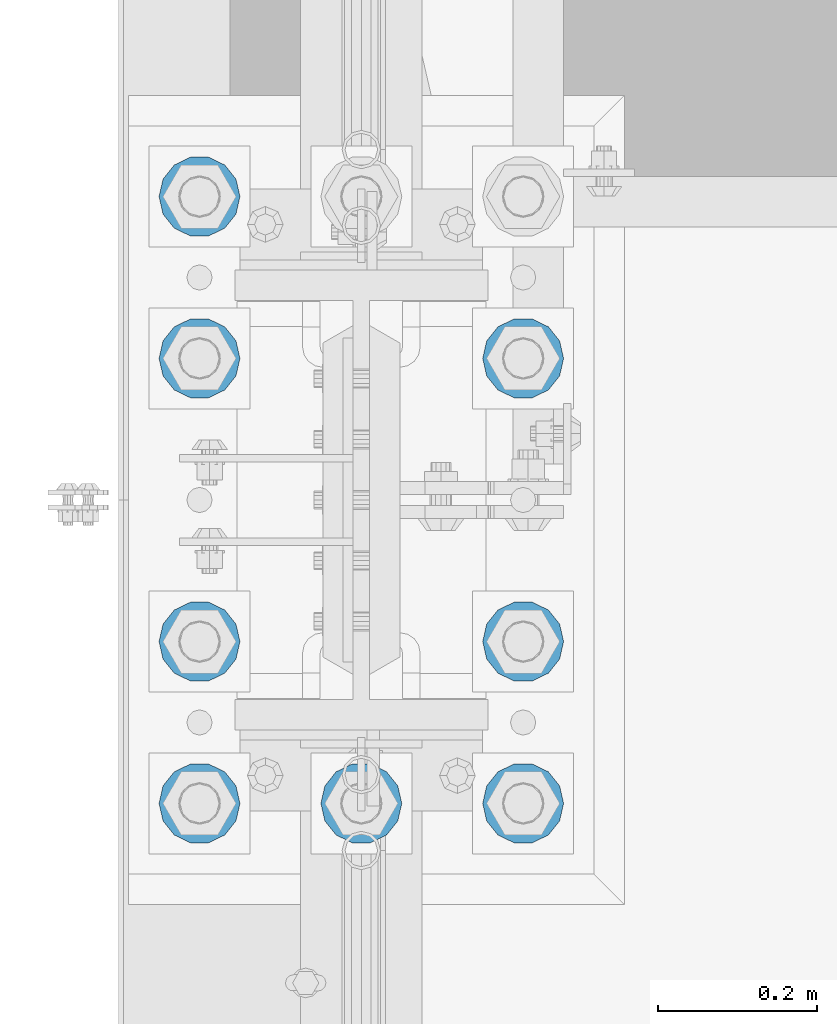
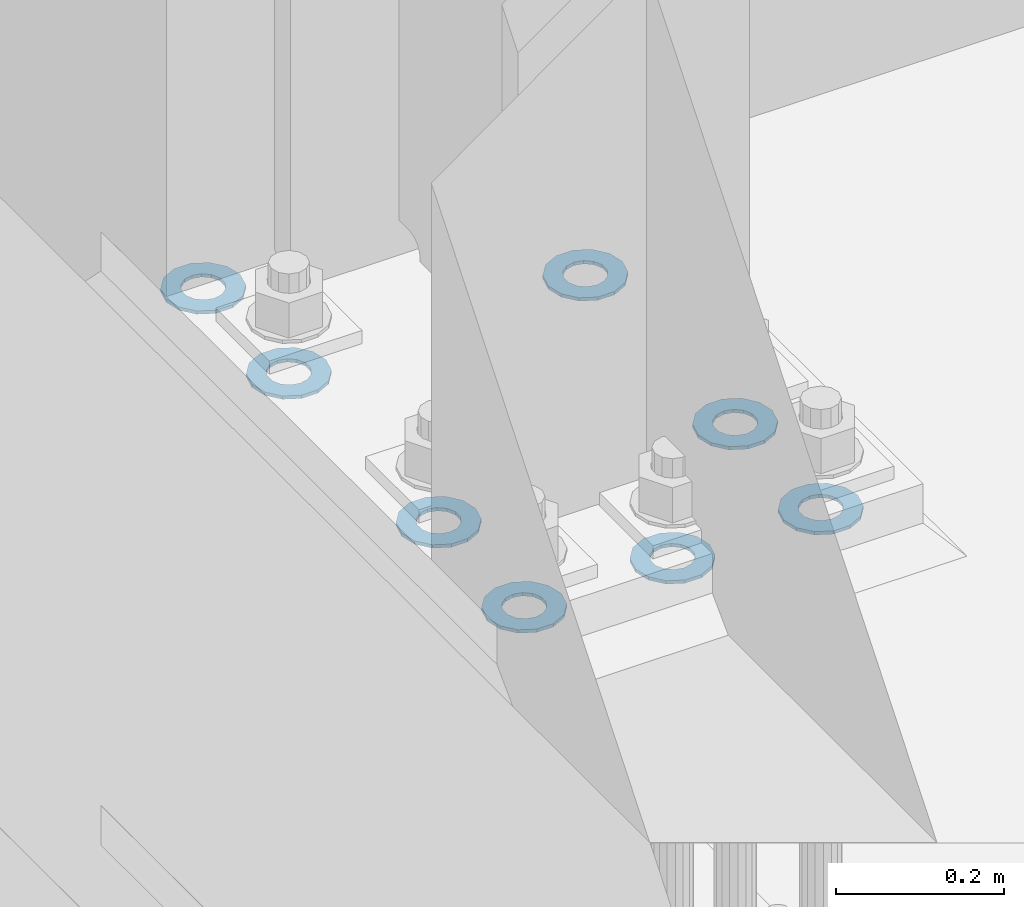
# One storey, part 833 of 1876: 8 columns, 1 element without a shape of its own.
"""IFC2X3 building model written with IfcOpenShell, lengths in millimetres."""

from ifc_helpers import new_model, si_unit, frame, origin_with_axes, place, context, subcontext, project, spatial, faceted_brep, material, type_object, element, aggregate, save


model = new_model("IFC2X3")

# Units and contexts
model_context = context("Model", 3, precision=1e-05, world=origin_with_axes())
body_context = subcontext(model_context, "Body", "Model", "MODEL_VIEW")
ifc_project = project(units=[si_unit("LENGTHUNIT", "METRE", prefix="MILLI"), si_unit("AREAUNIT", "SQUARE_METRE"), si_unit("VOLUMEUNIT", "CUBIC_METRE"), si_unit("MASSUNIT", "GRAM", prefix="KILO"), si_unit("TIMEUNIT", "SECOND"), si_unit("PLANEANGLEUNIT", "RADIAN"), si_unit("SOLIDANGLEUNIT", "STERADIAN"), si_unit("THERMODYNAMICTEMPERATUREUNIT", "DEGREE_CELSIUS"), si_unit("LUMINOUSINTENSITYUNIT", "LUMEN")], contexts=[model_context])

# Site, building, storey
site_placement = place(None, origin_with_axes())
site = spatial("IfcSite", under=ifc_project, at=site_placement, CompositionType="ELEMENT")
building_placement = place(site_placement, origin_with_axes())
building = spatial("IfcBuilding", under=site, at=building_placement, Name="Undefined", CompositionType="ELEMENT")
storey_placement = place(building_placement, origin_with_axes())
storey = spatial("IfcBuildingStorey", under=building, at=storey_placement, Name="Undefined", CompositionType="ELEMENT", Elevation=0.0)

# Assembly, columns
assembly_placement = place(storey_placement, origin_with_axes())
assembly = element("IfcElementAssembly", 1, at=assembly_placement, inside=storey, Name="TEMPLATE", AssemblyPlace="NOTDEFINED", PredefinedType="RIGID_FRAME")
ifc_material = material(Name="STEEL/F436")
column_type = type_object("IfcColumnType", Name="2_WASHER", PredefinedType="NOTDEFINED")
column_1_placement = place(assembly_placement, frame((-203.2, 1143.0, 38.1), z_axis=(0.0, -1.0, 0.0), x_axis=(0.0, 0.0, -1.0)))
column_1 = element("IfcColumn", 2, at=column_1_placement, type_object=column_type, material=ifc_material, Name="WASHER", ObjectType="2_WASHER", context=body_context, shape_type="Brep", body=[
    faceted_brep([(0.0, -50.7999992370605, 9.09494701772928e-13), (0.0, -45.7692178020588, -22.0412936161442), (4.7625, -45.7692178020588, -22.0412936161442), (4.7625, -50.7999992370605, 9.09494701772928e-13), (0.0, -31.6732814587394, -39.7170387128856), (4.7625, -31.6732814587394, -39.7170387128856), (0.0, -11.3040632752118, -49.5263371950259), (4.7625, -11.3040632752118, -49.5263371950259), (0.0, 11.30406327521, -49.5263371950264), (4.7625, 11.30406327521, -49.5263371950264), (0.0, 31.6732814587385, -39.7170387128867), (4.7625, 31.6732814587385, -39.7170387128867), (0.0, 45.7692178020579, -22.041293616146), (4.7625, 45.7692178020579, -22.041293616146), (0.0, 50.7999992370605, -9.09494701772928e-13), (4.7625, 50.7999992370605, -9.09494701772928e-13), (0.0, 45.7692178020588, 22.0412936161442), (4.7625, 45.7692178020588, 22.0412936161442), (0.0, 31.6732814587394, 39.7170387128856), (4.7625, 31.6732814587394, 39.7170387128856), (0.0, 11.3040632752118, 49.5263371950259), (4.7625, 11.3040632752118, 49.5263371950259), (0.0, -11.30406327521, 49.5263371950264), (4.7625, -11.30406327521, 49.5263371950264), (0.0, -31.6732814587385, 39.7170387128867), (4.7625, -31.6732814587385, 39.7170387128867), (0.0, -45.7692178020579, 22.041293616146), (4.7625, -45.7692178020579, 22.041293616146), (0.0, 0.0, 26.9869995117188), (0.0, 11.7093983825444, 24.3146012721213), (4.7625, 11.7093983825444, 24.3146012721213), (4.7625, 0.0, 26.9869995117188), (0.0, 21.0996520289491, 16.8262864224157), (4.7625, 21.0996520289491, 16.8262864224157), (0.0, 26.3108629296712, 6.00524193584533), (4.7625, 26.3108629296712, 6.00524193584533), (0.0, 26.3108629296712, -6.00524193584533), (4.7625, 26.3108629296712, -6.00524193584533), (0.0, 21.0996520289491, -16.8262864224157), (4.7625, 21.0996520289491, -16.8262864224157), (0.0, 11.7093983825444, -24.3146012721213), (4.7625, 11.7093983825444, -24.3146012721213), (0.0, 0.0, -26.9869995117188), (4.7625, 0.0, -26.9869995117188), (0.0, -11.7093983825444, -24.3146012721213), (4.7625, -11.7093983825444, -24.3146012721213), (0.0, -21.0996520289491, -16.8262864224157), (4.7625, -21.0996520289491, -16.8262864224157), (0.0, -26.3108629296712, -6.00524193584533), (4.7625, -26.3108629296712, -6.00524193584533), (0.0, -26.3108629296712, 6.00524193584533), (4.7625, -26.3108629296712, 6.00524193584533), (0.0, -21.0996520289491, 16.8262864224157), (4.7625, -21.0996520289491, 16.8262864224157), (0.0, -11.7093983825444, 24.3146012721213), (4.7625, -11.7093983825444, 24.3146012721213)], [[[0, 1, 2, 3]], [[1, 4, 5, 2]], [[4, 6, 7, 5]], [[6, 8, 9, 7]], [[8, 10, 11, 9]], [[10, 12, 13, 11]], [[12, 14, 15, 13]], [[14, 16, 17, 15]], [[16, 18, 19, 17]], [[18, 20, 21, 19]], [[20, 22, 23, 21]], [[22, 24, 25, 23]], [[24, 26, 27, 25]], [[26, 0, 3, 27]], [[28, 29, 30, 31]], [[29, 32, 33, 30]], [[32, 34, 35, 33]], [[34, 36, 37, 35]], [[36, 38, 39, 37]], [[38, 40, 41, 39]], [[40, 42, 43, 41]], [[42, 44, 45, 43]], [[44, 46, 47, 45]], [[46, 48, 49, 47]], [[48, 50, 51, 49]], [[50, 52, 53, 51]], [[52, 54, 55, 53]], [[54, 28, 31, 55]], [[5, 7, 9, 11, 13, 15, 17, 19, 21, 23, 25, 27, 3, 2], [33, 35, 37, 39, 41, 43, 45, 47, 49, 51, 53, 55, 31, 30]], [[26, 24, 22, 20, 18, 16, 14, 12, 10, 8, 6, 4, 1, 0], [54, 52, 50, 48, 46, 44, 42, 40, 38, 36, 34, 32, 29, 28]]]),
])
column_2_placement = place(assembly_placement, frame((0.0, 1143.0, 38.1), z_axis=(0.0, -1.0, 0.0), x_axis=(0.0, 0.0, -1.0)))
column_2 = element("IfcColumn", 3, at=column_2_placement, type_object=column_type, material=ifc_material, Name="WASHER", ObjectType="2_WASHER", context=body_context, shape_type="Brep", body=[
    faceted_brep([(0.0, -50.7999992370605, 9.09494701772928e-13), (0.0, -45.7692178020588, -22.0412936161442), (4.7625, -45.7692178020588, -22.0412936161442), (4.7625, -50.7999992370605, 9.09494701772928e-13), (0.0, -31.6732814587394, -39.7170387128856), (4.7625, -31.6732814587394, -39.7170387128856), (0.0, -11.3040632752118, -49.5263371950259), (4.7625, -11.3040632752118, -49.5263371950259), (0.0, 11.30406327521, -49.5263371950264), (4.7625, 11.30406327521, -49.5263371950264), (0.0, 31.6732814587385, -39.7170387128867), (4.7625, 31.6732814587385, -39.7170387128867), (0.0, 45.7692178020579, -22.041293616146), (4.7625, 45.7692178020579, -22.041293616146), (0.0, 50.7999992370605, -9.09494701772928e-13), (4.7625, 50.7999992370605, -9.09494701772928e-13), (0.0, 45.7692178020588, 22.0412936161442), (4.7625, 45.7692178020588, 22.0412936161442), (0.0, 31.6732814587394, 39.7170387128856), (4.7625, 31.6732814587394, 39.7170387128856), (0.0, 11.3040632752118, 49.5263371950259), (4.7625, 11.3040632752118, 49.5263371950259), (0.0, -11.30406327521, 49.5263371950264), (4.7625, -11.30406327521, 49.5263371950264), (0.0, -31.6732814587385, 39.7170387128867), (4.7625, -31.6732814587385, 39.7170387128867), (0.0, -45.7692178020579, 22.041293616146), (4.7625, -45.7692178020579, 22.041293616146), (0.0, 0.0, 26.9869995117188), (0.0, 11.7093983825444, 24.3146012721213), (4.7625, 11.7093983825444, 24.3146012721213), (4.7625, 0.0, 26.9869995117188), (0.0, 21.0996520289491, 16.8262864224157), (4.7625, 21.0996520289491, 16.8262864224157), (0.0, 26.3108629296712, 6.00524193584533), (4.7625, 26.3108629296712, 6.00524193584533), (0.0, 26.3108629296712, -6.00524193584533), (4.7625, 26.3108629296712, -6.00524193584533), (0.0, 21.0996520289491, -16.8262864224157), (4.7625, 21.0996520289491, -16.8262864224157), (0.0, 11.7093983825444, -24.3146012721213), (4.7625, 11.7093983825444, -24.3146012721213), (0.0, 0.0, -26.9869995117188), (4.7625, 0.0, -26.9869995117188), (0.0, -11.7093983825444, -24.3146012721213), (4.7625, -11.7093983825444, -24.3146012721213), (0.0, -21.0996520289491, -16.8262864224157), (4.7625, -21.0996520289491, -16.8262864224157), (0.0, -26.3108629296712, -6.00524193584533), (4.7625, -26.3108629296712, -6.00524193584533), (0.0, -26.3108629296712, 6.00524193584533), (4.7625, -26.3108629296712, 6.00524193584533), (0.0, -21.0996520289491, 16.8262864224157), (4.7625, -21.0996520289491, 16.8262864224157), (0.0, -11.7093983825444, 24.3146012721213), (4.7625, -11.7093983825444, 24.3146012721213)], [[[0, 1, 2, 3]], [[1, 4, 5, 2]], [[4, 6, 7, 5]], [[6, 8, 9, 7]], [[8, 10, 11, 9]], [[10, 12, 13, 11]], [[12, 14, 15, 13]], [[14, 16, 17, 15]], [[16, 18, 19, 17]], [[18, 20, 21, 19]], [[20, 22, 23, 21]], [[22, 24, 25, 23]], [[24, 26, 27, 25]], [[26, 0, 3, 27]], [[28, 29, 30, 31]], [[29, 32, 33, 30]], [[32, 34, 35, 33]], [[34, 36, 37, 35]], [[36, 38, 39, 37]], [[38, 40, 41, 39]], [[40, 42, 43, 41]], [[42, 44, 45, 43]], [[44, 46, 47, 45]], [[46, 48, 49, 47]], [[48, 50, 51, 49]], [[50, 52, 53, 51]], [[52, 54, 55, 53]], [[54, 28, 31, 55]], [[5, 7, 9, 11, 13, 15, 17, 19, 21, 23, 25, 27, 3, 2], [33, 35, 37, 39, 41, 43, 45, 47, 49, 51, 53, 55, 31, 30]], [[26, 24, 22, 20, 18, 16, 14, 12, 10, 8, 6, 4, 1, 0], [54, 52, 50, 48, 46, 44, 42, 40, 38, 36, 34, 32, 29, 28]]]),
])
column_3_placement = place(assembly_placement, frame((203.2, 1143.0, 38.1), z_axis=(0.0, 1.0, 0.0), x_axis=(0.0, 0.0, -1.0)))
column_3 = element("IfcColumn", 4, at=column_3_placement, type_object=column_type, material=ifc_material, Name="WASHER", ObjectType="2_WASHER", context=body_context, shape_type="Brep", body=[
    faceted_brep([(0.0, -50.7999992370605, 9.09494701772928e-13), (0.0, -45.7692178020588, -22.0412936161442), (4.7625, -45.7692178020588, -22.0412936161442), (4.7625, -50.7999992370605, 9.09494701772928e-13), (0.0, -31.6732814587394, -39.7170387128856), (4.7625, -31.6732814587394, -39.7170387128856), (0.0, -11.3040632752118, -49.5263371950259), (4.7625, -11.3040632752118, -49.5263371950259), (0.0, 11.30406327521, -49.5263371950264), (4.7625, 11.30406327521, -49.5263371950264), (0.0, 31.6732814587385, -39.7170387128867), (4.7625, 31.6732814587385, -39.7170387128867), (0.0, 45.7692178020579, -22.041293616146), (4.7625, 45.7692178020579, -22.041293616146), (0.0, 50.7999992370605, -9.09494701772928e-13), (4.7625, 50.7999992370605, -9.09494701772928e-13), (0.0, 45.7692178020588, 22.0412936161442), (4.7625, 45.7692178020588, 22.0412936161442), (0.0, 31.6732814587394, 39.7170387128856), (4.7625, 31.6732814587394, 39.7170387128856), (0.0, 11.3040632752118, 49.5263371950259), (4.7625, 11.3040632752118, 49.5263371950259), (0.0, -11.30406327521, 49.5263371950264), (4.7625, -11.30406327521, 49.5263371950264), (0.0, -31.6732814587385, 39.7170387128867), (4.7625, -31.6732814587385, 39.7170387128867), (0.0, -45.7692178020579, 22.041293616146), (4.7625, -45.7692178020579, 22.041293616146), (0.0, 0.0, 26.9869995117188), (0.0, 11.7093983825444, 24.3146012721213), (4.7625, 11.7093983825444, 24.3146012721213), (4.7625, 0.0, 26.9869995117188), (0.0, 21.0996520289491, 16.8262864224157), (4.7625, 21.0996520289491, 16.8262864224157), (0.0, 26.3108629296712, 6.00524193584533), (4.7625, 26.3108629296712, 6.00524193584533), (0.0, 26.3108629296712, -6.00524193584533), (4.7625, 26.3108629296712, -6.00524193584533), (0.0, 21.0996520289491, -16.8262864224157), (4.7625, 21.0996520289491, -16.8262864224157), (0.0, 11.7093983825444, -24.3146012721213), (4.7625, 11.7093983825444, -24.3146012721213), (0.0, 0.0, -26.9869995117188), (4.7625, 0.0, -26.9869995117188), (0.0, -11.7093983825444, -24.3146012721213), (4.7625, -11.7093983825444, -24.3146012721213), (0.0, -21.0996520289491, -16.8262864224157), (4.7625, -21.0996520289491, -16.8262864224157), (0.0, -26.3108629296712, -6.00524193584533), (4.7625, -26.3108629296712, -6.00524193584533), (0.0, -26.3108629296712, 6.00524193584533), (4.7625, -26.3108629296712, 6.00524193584533), (0.0, -21.0996520289491, 16.8262864224157), (4.7625, -21.0996520289491, 16.8262864224157), (0.0, -11.7093983825444, 24.3146012721213), (4.7625, -11.7093983825444, 24.3146012721213)], [[[0, 1, 2, 3]], [[1, 4, 5, 2]], [[4, 6, 7, 5]], [[6, 8, 9, 7]], [[8, 10, 11, 9]], [[10, 12, 13, 11]], [[12, 14, 15, 13]], [[14, 16, 17, 15]], [[16, 18, 19, 17]], [[18, 20, 21, 19]], [[20, 22, 23, 21]], [[22, 24, 25, 23]], [[24, 26, 27, 25]], [[26, 0, 3, 27]], [[28, 29, 30, 31]], [[29, 32, 33, 30]], [[32, 34, 35, 33]], [[34, 36, 37, 35]], [[36, 38, 39, 37]], [[38, 40, 41, 39]], [[40, 42, 43, 41]], [[42, 44, 45, 43]], [[44, 46, 47, 45]], [[46, 48, 49, 47]], [[48, 50, 51, 49]], [[50, 52, 53, 51]], [[52, 54, 55, 53]], [[54, 28, 31, 55]], [[5, 7, 9, 11, 13, 15, 17, 19, 21, 23, 25, 27, 3, 2], [33, 35, 37, 39, 41, 43, 45, 47, 49, 51, 53, 55, 31, 30]], [[26, 24, 22, 20, 18, 16, 14, 12, 10, 8, 6, 4, 1, 0], [54, 52, 50, 48, 46, 44, 42, 40, 38, 36, 34, 32, 29, 28]]]),
])
column_4_placement = place(assembly_placement, frame((-203.2, 1346.2, 38.1), z_axis=(0.0, -1.0, 0.0), x_axis=(0.0, 0.0, -1.0)))
column_4 = element("IfcColumn", 5, at=column_4_placement, type_object=column_type, material=ifc_material, Name="WASHER", ObjectType="2_WASHER", context=body_context, shape_type="Brep", body=[
    faceted_brep([(0.0, -50.7999992370605, 9.09494701772928e-13), (0.0, -45.7692178020588, -22.0412936161442), (4.7625, -45.7692178020588, -22.0412936161442), (4.7625, -50.7999992370605, 9.09494701772928e-13), (0.0, -31.6732814587394, -39.7170387128856), (4.7625, -31.6732814587394, -39.7170387128856), (0.0, -11.3040632752118, -49.5263371950259), (4.7625, -11.3040632752118, -49.5263371950259), (0.0, 11.30406327521, -49.5263371950264), (4.7625, 11.30406327521, -49.5263371950264), (0.0, 31.6732814587385, -39.7170387128867), (4.7625, 31.6732814587385, -39.7170387128867), (0.0, 45.7692178020579, -22.041293616146), (4.7625, 45.7692178020579, -22.041293616146), (0.0, 50.7999992370605, -9.09494701772928e-13), (4.7625, 50.7999992370605, -9.09494701772928e-13), (0.0, 45.7692178020588, 22.0412936161442), (4.7625, 45.7692178020588, 22.0412936161442), (0.0, 31.6732814587394, 39.7170387128856), (4.7625, 31.6732814587394, 39.7170387128856), (0.0, 11.3040632752118, 49.5263371950259), (4.7625, 11.3040632752118, 49.5263371950259), (0.0, -11.30406327521, 49.5263371950264), (4.7625, -11.30406327521, 49.5263371950264), (0.0, -31.6732814587385, 39.7170387128867), (4.7625, -31.6732814587385, 39.7170387128867), (0.0, -45.7692178020579, 22.041293616146), (4.7625, -45.7692178020579, 22.041293616146), (0.0, 0.0, 26.9869995117188), (0.0, 11.7093983825444, 24.3146012721213), (4.7625, 11.7093983825444, 24.3146012721213), (4.7625, 0.0, 26.9869995117188), (0.0, 21.0996520289491, 16.8262864224157), (4.7625, 21.0996520289491, 16.8262864224157), (0.0, 26.3108629296712, 6.00524193584533), (4.7625, 26.3108629296712, 6.00524193584533), (0.0, 26.3108629296712, -6.00524193584533), (4.7625, 26.3108629296712, -6.00524193584533), (0.0, 21.0996520289491, -16.8262864224157), (4.7625, 21.0996520289491, -16.8262864224157), (0.0, 11.7093983825444, -24.3146012721213), (4.7625, 11.7093983825444, -24.3146012721213), (0.0, 0.0, -26.9869995117188), (4.7625, 0.0, -26.9869995117188), (0.0, -11.7093983825444, -24.3146012721213), (4.7625, -11.7093983825444, -24.3146012721213), (0.0, -21.0996520289491, -16.8262864224157), (4.7625, -21.0996520289491, -16.8262864224157), (0.0, -26.3108629296712, -6.00524193584533), (4.7625, -26.3108629296712, -6.00524193584533), (0.0, -26.3108629296712, 6.00524193584533), (4.7625, -26.3108629296712, 6.00524193584533), (0.0, -21.0996520289491, 16.8262864224157), (4.7625, -21.0996520289491, 16.8262864224157), (0.0, -11.7093983825444, 24.3146012721213), (4.7625, -11.7093983825444, 24.3146012721213)], [[[0, 1, 2, 3]], [[1, 4, 5, 2]], [[4, 6, 7, 5]], [[6, 8, 9, 7]], [[8, 10, 11, 9]], [[10, 12, 13, 11]], [[12, 14, 15, 13]], [[14, 16, 17, 15]], [[16, 18, 19, 17]], [[18, 20, 21, 19]], [[20, 22, 23, 21]], [[22, 24, 25, 23]], [[24, 26, 27, 25]], [[26, 0, 3, 27]], [[28, 29, 30, 31]], [[29, 32, 33, 30]], [[32, 34, 35, 33]], [[34, 36, 37, 35]], [[36, 38, 39, 37]], [[38, 40, 41, 39]], [[40, 42, 43, 41]], [[42, 44, 45, 43]], [[44, 46, 47, 45]], [[46, 48, 49, 47]], [[48, 50, 51, 49]], [[50, 52, 53, 51]], [[52, 54, 55, 53]], [[54, 28, 31, 55]], [[5, 7, 9, 11, 13, 15, 17, 19, 21, 23, 25, 27, 3, 2], [33, 35, 37, 39, 41, 43, 45, 47, 49, 51, 53, 55, 31, 30]], [[26, 24, 22, 20, 18, 16, 14, 12, 10, 8, 6, 4, 1, 0], [54, 52, 50, 48, 46, 44, 42, 40, 38, 36, 34, 32, 29, 28]]]),
])
column_5_placement = place(assembly_placement, frame((203.2, 1346.2, 38.1), z_axis=(0.0, 1.0, 0.0), x_axis=(0.0, 0.0, -1.0)))
column_5 = element("IfcColumn", 6, at=column_5_placement, type_object=column_type, material=ifc_material, Name="WASHER", ObjectType="2_WASHER", context=body_context, shape_type="Brep", body=[
    faceted_brep([(0.0, -50.7999992370605, 9.09494701772928e-13), (0.0, -45.7692178020588, -22.0412936161442), (4.7625, -45.7692178020588, -22.0412936161442), (4.7625, -50.7999992370605, 9.09494701772928e-13), (0.0, -31.6732814587394, -39.7170387128856), (4.7625, -31.6732814587394, -39.7170387128856), (0.0, -11.3040632752118, -49.5263371950259), (4.7625, -11.3040632752118, -49.5263371950259), (0.0, 11.30406327521, -49.5263371950264), (4.7625, 11.30406327521, -49.5263371950264), (0.0, 31.6732814587385, -39.7170387128867), (4.7625, 31.6732814587385, -39.7170387128867), (0.0, 45.7692178020579, -22.041293616146), (4.7625, 45.7692178020579, -22.041293616146), (0.0, 50.7999992370605, -9.09494701772928e-13), (4.7625, 50.7999992370605, -9.09494701772928e-13), (0.0, 45.7692178020588, 22.0412936161442), (4.7625, 45.7692178020588, 22.0412936161442), (0.0, 31.6732814587394, 39.7170387128856), (4.7625, 31.6732814587394, 39.7170387128856), (0.0, 11.3040632752118, 49.5263371950259), (4.7625, 11.3040632752118, 49.5263371950259), (0.0, -11.30406327521, 49.5263371950264), (4.7625, -11.30406327521, 49.5263371950264), (0.0, -31.6732814587385, 39.7170387128867), (4.7625, -31.6732814587385, 39.7170387128867), (0.0, -45.7692178020579, 22.041293616146), (4.7625, -45.7692178020579, 22.041293616146), (0.0, 0.0, 26.9869995117188), (0.0, 11.7093983825444, 24.3146012721213), (4.7625, 11.7093983825444, 24.3146012721213), (4.7625, 0.0, 26.9869995117188), (0.0, 21.0996520289491, 16.8262864224157), (4.7625, 21.0996520289491, 16.8262864224157), (0.0, 26.3108629296712, 6.00524193584533), (4.7625, 26.3108629296712, 6.00524193584533), (0.0, 26.3108629296712, -6.00524193584533), (4.7625, 26.3108629296712, -6.00524193584533), (0.0, 21.0996520289491, -16.8262864224157), (4.7625, 21.0996520289491, -16.8262864224157), (0.0, 11.7093983825444, -24.3146012721213), (4.7625, 11.7093983825444, -24.3146012721213), (0.0, 0.0, -26.9869995117188), (4.7625, 0.0, -26.9869995117188), (0.0, -11.7093983825444, -24.3146012721213), (4.7625, -11.7093983825444, -24.3146012721213), (0.0, -21.0996520289491, -16.8262864224157), (4.7625, -21.0996520289491, -16.8262864224157), (0.0, -26.3108629296712, -6.00524193584533), (4.7625, -26.3108629296712, -6.00524193584533), (0.0, -26.3108629296712, 6.00524193584533), (4.7625, -26.3108629296712, 6.00524193584533), (0.0, -21.0996520289491, 16.8262864224157), (4.7625, -21.0996520289491, 16.8262864224157), (0.0, -11.7093983825444, 24.3146012721213), (4.7625, -11.7093983825444, 24.3146012721213)], [[[0, 1, 2, 3]], [[1, 4, 5, 2]], [[4, 6, 7, 5]], [[6, 8, 9, 7]], [[8, 10, 11, 9]], [[10, 12, 13, 11]], [[12, 14, 15, 13]], [[14, 16, 17, 15]], [[16, 18, 19, 17]], [[18, 20, 21, 19]], [[20, 22, 23, 21]], [[22, 24, 25, 23]], [[24, 26, 27, 25]], [[26, 0, 3, 27]], [[28, 29, 30, 31]], [[29, 32, 33, 30]], [[32, 34, 35, 33]], [[34, 36, 37, 35]], [[36, 38, 39, 37]], [[38, 40, 41, 39]], [[40, 42, 43, 41]], [[42, 44, 45, 43]], [[44, 46, 47, 45]], [[46, 48, 49, 47]], [[48, 50, 51, 49]], [[50, 52, 53, 51]], [[52, 54, 55, 53]], [[54, 28, 31, 55]], [[5, 7, 9, 11, 13, 15, 17, 19, 21, 23, 25, 27, 3, 2], [33, 35, 37, 39, 41, 43, 45, 47, 49, 51, 53, 55, 31, 30]], [[26, 24, 22, 20, 18, 16, 14, 12, 10, 8, 6, 4, 1, 0], [54, 52, 50, 48, 46, 44, 42, 40, 38, 36, 34, 32, 29, 28]]]),
])
column_6_placement = place(assembly_placement, frame((-203.2, 1701.8, 38.1), z_axis=(0.0, -1.0, 0.0), x_axis=(0.0, 0.0, -1.0)))
column_6 = element("IfcColumn", 7, at=column_6_placement, type_object=column_type, material=ifc_material, Name="WASHER", ObjectType="2_WASHER", context=body_context, shape_type="Brep", body=[
    faceted_brep([(0.0, -50.7999992370605, 9.09494701772928e-13), (0.0, -45.7692178020588, -22.0412936161442), (4.7625, -45.7692178020588, -22.0412936161442), (4.7625, -50.7999992370605, 9.09494701772928e-13), (0.0, -31.6732814587394, -39.7170387128856), (4.7625, -31.6732814587394, -39.7170387128856), (0.0, -11.3040632752118, -49.5263371950259), (4.7625, -11.3040632752118, -49.5263371950259), (0.0, 11.30406327521, -49.5263371950264), (4.7625, 11.30406327521, -49.5263371950264), (0.0, 31.6732814587385, -39.7170387128867), (4.7625, 31.6732814587385, -39.7170387128867), (0.0, 45.7692178020579, -22.041293616146), (4.7625, 45.7692178020579, -22.041293616146), (0.0, 50.7999992370605, -9.09494701772928e-13), (4.7625, 50.7999992370605, -9.09494701772928e-13), (0.0, 45.7692178020588, 22.0412936161442), (4.7625, 45.7692178020588, 22.0412936161442), (0.0, 31.6732814587394, 39.7170387128856), (4.7625, 31.6732814587394, 39.7170387128856), (0.0, 11.3040632752118, 49.5263371950259), (4.7625, 11.3040632752118, 49.5263371950259), (0.0, -11.30406327521, 49.5263371950264), (4.7625, -11.30406327521, 49.5263371950264), (0.0, -31.6732814587385, 39.7170387128867), (4.7625, -31.6732814587385, 39.7170387128867), (0.0, -45.7692178020579, 22.041293616146), (4.7625, -45.7692178020579, 22.041293616146), (0.0, 0.0, 26.9869995117188), (0.0, 11.7093983825444, 24.3146012721213), (4.7625, 11.7093983825444, 24.3146012721213), (4.7625, 0.0, 26.9869995117188), (0.0, 21.0996520289491, 16.8262864224157), (4.7625, 21.0996520289491, 16.8262864224157), (0.0, 26.3108629296712, 6.00524193584533), (4.7625, 26.3108629296712, 6.00524193584533), (0.0, 26.3108629296712, -6.00524193584533), (4.7625, 26.3108629296712, -6.00524193584533), (0.0, 21.0996520289491, -16.8262864224157), (4.7625, 21.0996520289491, -16.8262864224157), (0.0, 11.7093983825444, -24.3146012721213), (4.7625, 11.7093983825444, -24.3146012721213), (0.0, 0.0, -26.9869995117188), (4.7625, 0.0, -26.9869995117188), (0.0, -11.7093983825444, -24.3146012721213), (4.7625, -11.7093983825444, -24.3146012721213), (0.0, -21.0996520289491, -16.8262864224157), (4.7625, -21.0996520289491, -16.8262864224157), (0.0, -26.3108629296712, -6.00524193584533), (4.7625, -26.3108629296712, -6.00524193584533), (0.0, -26.3108629296712, 6.00524193584533), (4.7625, -26.3108629296712, 6.00524193584533), (0.0, -21.0996520289491, 16.8262864224157), (4.7625, -21.0996520289491, 16.8262864224157), (0.0, -11.7093983825444, 24.3146012721213), (4.7625, -11.7093983825444, 24.3146012721213)], [[[0, 1, 2, 3]], [[1, 4, 5, 2]], [[4, 6, 7, 5]], [[6, 8, 9, 7]], [[8, 10, 11, 9]], [[10, 12, 13, 11]], [[12, 14, 15, 13]], [[14, 16, 17, 15]], [[16, 18, 19, 17]], [[18, 20, 21, 19]], [[20, 22, 23, 21]], [[22, 24, 25, 23]], [[24, 26, 27, 25]], [[26, 0, 3, 27]], [[28, 29, 30, 31]], [[29, 32, 33, 30]], [[32, 34, 35, 33]], [[34, 36, 37, 35]], [[36, 38, 39, 37]], [[38, 40, 41, 39]], [[40, 42, 43, 41]], [[42, 44, 45, 43]], [[44, 46, 47, 45]], [[46, 48, 49, 47]], [[48, 50, 51, 49]], [[50, 52, 53, 51]], [[52, 54, 55, 53]], [[54, 28, 31, 55]], [[5, 7, 9, 11, 13, 15, 17, 19, 21, 23, 25, 27, 3, 2], [33, 35, 37, 39, 41, 43, 45, 47, 49, 51, 53, 55, 31, 30]], [[26, 24, 22, 20, 18, 16, 14, 12, 10, 8, 6, 4, 1, 0], [54, 52, 50, 48, 46, 44, 42, 40, 38, 36, 34, 32, 29, 28]]]),
])
column_7_placement = place(assembly_placement, frame((203.2, 1701.8, 38.1), z_axis=(0.0, 1.0, 0.0), x_axis=(0.0, 0.0, -1.0)))
column_7 = element("IfcColumn", 8, at=column_7_placement, type_object=column_type, material=ifc_material, Name="WASHER", ObjectType="2_WASHER", context=body_context, shape_type="Brep", body=[
    faceted_brep([(0.0, -50.7999992370605, 9.09494701772928e-13), (0.0, -45.7692178020588, -22.0412936161442), (4.7625, -45.7692178020588, -22.0412936161442), (4.7625, -50.7999992370605, 9.09494701772928e-13), (0.0, -31.6732814587394, -39.7170387128856), (4.7625, -31.6732814587394, -39.7170387128856), (0.0, -11.3040632752118, -49.5263371950259), (4.7625, -11.3040632752118, -49.5263371950259), (0.0, 11.30406327521, -49.5263371950264), (4.7625, 11.30406327521, -49.5263371950264), (0.0, 31.6732814587385, -39.7170387128867), (4.7625, 31.6732814587385, -39.7170387128867), (0.0, 45.7692178020579, -22.041293616146), (4.7625, 45.7692178020579, -22.041293616146), (0.0, 50.7999992370605, -9.09494701772928e-13), (4.7625, 50.7999992370605, -9.09494701772928e-13), (0.0, 45.7692178020588, 22.0412936161442), (4.7625, 45.7692178020588, 22.0412936161442), (0.0, 31.6732814587394, 39.7170387128856), (4.7625, 31.6732814587394, 39.7170387128856), (0.0, 11.3040632752118, 49.5263371950259), (4.7625, 11.3040632752118, 49.5263371950259), (0.0, -11.30406327521, 49.5263371950264), (4.7625, -11.30406327521, 49.5263371950264), (0.0, -31.6732814587385, 39.7170387128867), (4.7625, -31.6732814587385, 39.7170387128867), (0.0, -45.7692178020579, 22.041293616146), (4.7625, -45.7692178020579, 22.041293616146), (0.0, 0.0, 26.9869995117188), (0.0, 11.7093983825444, 24.3146012721213), (4.7625, 11.7093983825444, 24.3146012721213), (4.7625, 0.0, 26.9869995117188), (0.0, 21.0996520289491, 16.8262864224157), (4.7625, 21.0996520289491, 16.8262864224157), (0.0, 26.3108629296712, 6.00524193584533), (4.7625, 26.3108629296712, 6.00524193584533), (0.0, 26.3108629296712, -6.00524193584533), (4.7625, 26.3108629296712, -6.00524193584533), (0.0, 21.0996520289491, -16.8262864224157), (4.7625, 21.0996520289491, -16.8262864224157), (0.0, 11.7093983825444, -24.3146012721213), (4.7625, 11.7093983825444, -24.3146012721213), (0.0, 0.0, -26.9869995117188), (4.7625, 0.0, -26.9869995117188), (0.0, -11.7093983825444, -24.3146012721213), (4.7625, -11.7093983825444, -24.3146012721213), (0.0, -21.0996520289491, -16.8262864224157), (4.7625, -21.0996520289491, -16.8262864224157), (0.0, -26.3108629296712, -6.00524193584533), (4.7625, -26.3108629296712, -6.00524193584533), (0.0, -26.3108629296712, 6.00524193584533), (4.7625, -26.3108629296712, 6.00524193584533), (0.0, -21.0996520289491, 16.8262864224157), (4.7625, -21.0996520289491, 16.8262864224157), (0.0, -11.7093983825444, 24.3146012721213), (4.7625, -11.7093983825444, 24.3146012721213)], [[[0, 1, 2, 3]], [[1, 4, 5, 2]], [[4, 6, 7, 5]], [[6, 8, 9, 7]], [[8, 10, 11, 9]], [[10, 12, 13, 11]], [[12, 14, 15, 13]], [[14, 16, 17, 15]], [[16, 18, 19, 17]], [[18, 20, 21, 19]], [[20, 22, 23, 21]], [[22, 24, 25, 23]], [[24, 26, 27, 25]], [[26, 0, 3, 27]], [[28, 29, 30, 31]], [[29, 32, 33, 30]], [[32, 34, 35, 33]], [[34, 36, 37, 35]], [[36, 38, 39, 37]], [[38, 40, 41, 39]], [[40, 42, 43, 41]], [[42, 44, 45, 43]], [[44, 46, 47, 45]], [[46, 48, 49, 47]], [[48, 50, 51, 49]], [[50, 52, 53, 51]], [[52, 54, 55, 53]], [[54, 28, 31, 55]], [[5, 7, 9, 11, 13, 15, 17, 19, 21, 23, 25, 27, 3, 2], [33, 35, 37, 39, 41, 43, 45, 47, 49, 51, 53, 55, 31, 30]], [[26, 24, 22, 20, 18, 16, 14, 12, 10, 8, 6, 4, 1, 0], [54, 52, 50, 48, 46, 44, 42, 40, 38, 36, 34, 32, 29, 28]]]),
])
column_8_placement = place(assembly_placement, frame((-203.2, 1905.0, 38.1), z_axis=(0.0, -1.0, 0.0), x_axis=(0.0, 0.0, -1.0)))
column_8 = element("IfcColumn", 9, at=column_8_placement, type_object=column_type, material=ifc_material, Name="WASHER", ObjectType="2_WASHER", context=body_context, shape_type="Brep", body=[
    faceted_brep([(0.0, -50.7999992370605, 9.09494701772928e-13), (0.0, -45.7692178020588, -22.0412936161442), (4.7625, -45.7692178020588, -22.0412936161442), (4.7625, -50.7999992370605, 9.09494701772928e-13), (0.0, -31.6732814587394, -39.7170387128856), (4.7625, -31.6732814587394, -39.7170387128856), (0.0, -11.3040632752118, -49.5263371950259), (4.7625, -11.3040632752118, -49.5263371950259), (0.0, 11.30406327521, -49.5263371950264), (4.7625, 11.30406327521, -49.5263371950264), (0.0, 31.6732814587385, -39.7170387128867), (4.7625, 31.6732814587385, -39.7170387128867), (0.0, 45.7692178020579, -22.041293616146), (4.7625, 45.7692178020579, -22.041293616146), (0.0, 50.7999992370605, -9.09494701772928e-13), (4.7625, 50.7999992370605, -9.09494701772928e-13), (0.0, 45.7692178020588, 22.0412936161442), (4.7625, 45.7692178020588, 22.0412936161442), (0.0, 31.6732814587394, 39.7170387128856), (4.7625, 31.6732814587394, 39.7170387128856), (0.0, 11.3040632752118, 49.5263371950259), (4.7625, 11.3040632752118, 49.5263371950259), (0.0, -11.30406327521, 49.5263371950264), (4.7625, -11.30406327521, 49.5263371950264), (0.0, -31.6732814587385, 39.7170387128867), (4.7625, -31.6732814587385, 39.7170387128867), (0.0, -45.7692178020579, 22.041293616146), (4.7625, -45.7692178020579, 22.041293616146), (0.0, 0.0, 26.9869995117188), (0.0, 11.7093983825444, 24.3146012721213), (4.7625, 11.7093983825444, 24.3146012721213), (4.7625, 0.0, 26.9869995117188), (0.0, 21.0996520289491, 16.8262864224157), (4.7625, 21.0996520289491, 16.8262864224157), (0.0, 26.3108629296712, 6.00524193584533), (4.7625, 26.3108629296712, 6.00524193584533), (0.0, 26.3108629296712, -6.00524193584533), (4.7625, 26.3108629296712, -6.00524193584533), (0.0, 21.0996520289491, -16.8262864224157), (4.7625, 21.0996520289491, -16.8262864224157), (0.0, 11.7093983825444, -24.3146012721213), (4.7625, 11.7093983825444, -24.3146012721213), (0.0, 0.0, -26.9869995117188), (4.7625, 0.0, -26.9869995117188), (0.0, -11.7093983825444, -24.3146012721213), (4.7625, -11.7093983825444, -24.3146012721213), (0.0, -21.0996520289491, -16.8262864224157), (4.7625, -21.0996520289491, -16.8262864224157), (0.0, -26.3108629296712, -6.00524193584533), (4.7625, -26.3108629296712, -6.00524193584533), (0.0, -26.3108629296712, 6.00524193584533), (4.7625, -26.3108629296712, 6.00524193584533), (0.0, -21.0996520289491, 16.8262864224157), (4.7625, -21.0996520289491, 16.8262864224157), (0.0, -11.7093983825444, 24.3146012721213), (4.7625, -11.7093983825444, 24.3146012721213)], [[[0, 1, 2, 3]], [[1, 4, 5, 2]], [[4, 6, 7, 5]], [[6, 8, 9, 7]], [[8, 10, 11, 9]], [[10, 12, 13, 11]], [[12, 14, 15, 13]], [[14, 16, 17, 15]], [[16, 18, 19, 17]], [[18, 20, 21, 19]], [[20, 22, 23, 21]], [[22, 24, 25, 23]], [[24, 26, 27, 25]], [[26, 0, 3, 27]], [[28, 29, 30, 31]], [[29, 32, 33, 30]], [[32, 34, 35, 33]], [[34, 36, 37, 35]], [[36, 38, 39, 37]], [[38, 40, 41, 39]], [[40, 42, 43, 41]], [[42, 44, 45, 43]], [[44, 46, 47, 45]], [[46, 48, 49, 47]], [[48, 50, 51, 49]], [[50, 52, 53, 51]], [[52, 54, 55, 53]], [[54, 28, 31, 55]], [[5, 7, 9, 11, 13, 15, 17, 19, 21, 23, 25, 27, 3, 2], [33, 35, 37, 39, 41, 43, 45, 47, 49, 51, 53, 55, 31, 30]], [[26, 24, 22, 20, 18, 16, 14, 12, 10, 8, 6, 4, 1, 0], [54, 52, 50, 48, 46, 44, 42, 40, 38, 36, 34, 32, 29, 28]]]),
])
aggregate(assembly, [column_1, column_2, column_3, column_4, column_5, column_6, column_7, column_8])

save(model, "model.ifc")
